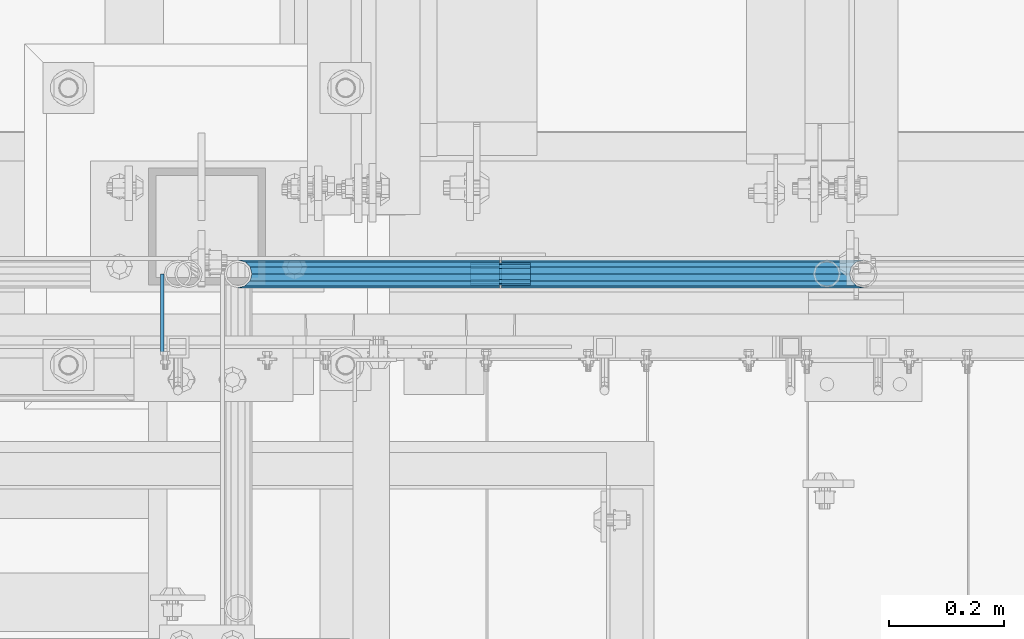
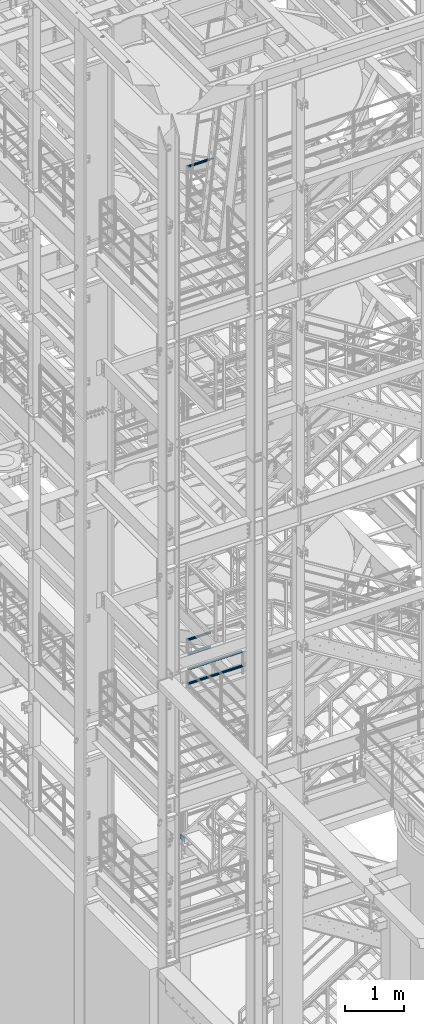
# One storey, part 1173 of 1876: 9 beams, 4 elements without a shape of their own.
"""IFC2X3 building model written with IfcOpenShell, lengths in millimetres."""

from ifc_helpers import new_model, si_unit, frame, origin_with_axes, place, context, subcontext, project, spatial, faceted_brep, material, type_object, element, aggregate, save


model = new_model("IFC2X3")

# Units and contexts
model_context = context("Model", 3, precision=1e-05, world=origin_with_axes())
body_context = subcontext(model_context, "Body", "Model", "MODEL_VIEW")
ifc_project = project(units=[si_unit("LENGTHUNIT", "METRE", prefix="MILLI"), si_unit("AREAUNIT", "SQUARE_METRE"), si_unit("VOLUMEUNIT", "CUBIC_METRE"), si_unit("MASSUNIT", "GRAM", prefix="KILO"), si_unit("TIMEUNIT", "SECOND"), si_unit("PLANEANGLEUNIT", "RADIAN"), si_unit("SOLIDANGLEUNIT", "STERADIAN"), si_unit("THERMODYNAMICTEMPERATUREUNIT", "DEGREE_CELSIUS"), si_unit("LUMINOUSINTENSITYUNIT", "LUMEN")], contexts=[model_context])

# Site, building, storey
site_placement = place(None, origin_with_axes())
site = spatial("IfcSite", under=ifc_project, at=site_placement, CompositionType="ELEMENT")
building_placement = place(site_placement, origin_with_axes())
building = spatial("IfcBuilding", under=site, at=building_placement, Name="Undefined", CompositionType="ELEMENT")
storey_placement = place(building_placement, origin_with_axes())
storey = spatial("IfcBuildingStorey", under=building, at=storey_placement, Name="Undefined", CompositionType="ELEMENT", Elevation=0.0)

# Assembly, beams
assembly_1_placement = place(storey_placement, origin_with_axes())
assembly_1 = element("IfcElementAssembly", 1, at=assembly_1_placement, inside=storey, Name="RAIL", AssemblyPlace="NOTDEFINED", PredefinedType="RIGID_FRAME")
ifc_material_1 = material()
beam_type_1 = type_object("IfcBeamType", Name="PIPE1-1/2SCH40", PredefinedType="NOTDEFINED")
beam_1_placement = place(assembly_1_placement, frame((2870.19999998823, -4654.55000114554, 8315.325), z_axis=(0.0, 0.0, 1.0), x_axis=(-1.0, 0.0, 0.0)))
beam_1 = element("IfcBeam", 2, at=beam_1_placement, type_object=beam_type_1, material=ifc_material_1, Name="RAIL", ObjectType="PIPE1-1/2SCH40", context=body_context, shape_type="Brep", body=[
    faceted_brep([(0.0, 24.1299999999992, 0.0), (12.0650000000064, 20.8971929933177, -12.0649999999987), (12.0650000000064, 20.8971929933177, 12.0649999999987), (12.0650000000064, -20.8971929933177, 12.0649999999987), (12.0650000000064, -20.8971929933177, -12.0649999999987), (0.0, -24.1299999999992, 0.0), (20.8971929933249, -12.0650000000005, 20.8971929933177), (20.8971929933249, -12.0650000000005, 15.8661214311796), (15.2545715621445, -17.7076214311801, 10.2235000000001), (12.5151929933249, -20.4470000000001, 0.0), (15.2545715621445, -17.7076214311801, -10.2235000000001), (20.8971929933249, -12.0650000000005, -15.8661214311796), (20.8971929933249, -12.0650000000005, -20.8971929933177), (24.1300000000063, 0.0, -20.4470000000001), (24.1300000000063, 0.0, -24.130000000001), (21.3906214311868, -10.2235000000001, -17.7076214311819), (21.3906214311868, 10.2235000000001, -17.7076214311819), (20.8971929933249, 12.0650000000005, -15.8661214311796), (20.8971929933249, 12.0650000000005, -20.8971929933177), (15.2545715621445, 17.7076214311801, -10.2235000000001), (12.5151929933249, 20.4470000000001, 0.0), (15.2545715621445, 17.7076214311801, 10.2235000000001), (20.8971929933249, 12.0650000000005, 15.8661214311796), (20.8971929933249, 12.0650000000005, 20.8971929933177), (21.3906214311868, 10.2235000000001, 17.7076214311819), (24.1300000000064, 0.0, 20.4470000000001), (24.1300000000064, 0.0, 24.130000000001), (21.3906214311868, -10.2235000000001, 17.7076214311819), (630.238000000001, -24.1300000000001, 0.0), (630.238000000001, -20.8971929933186, 12.0649999999987), (630.238000000001, -12.0649999999996, 20.8971929933177), (630.238000000001, 0.0, 24.130000000001), (630.238000000001, -12.0649999999996, -20.8971929933177), (630.238000000001, -20.8971929933186, -12.0649999999987), (630.238000000001, 0.0, -24.130000000001), (630.238000000001, 12.0649999999996, -20.8971929933177), (630.238000000001, 20.8971929933186, -12.0649999999987), (630.238000000001, 24.1300000000001, 0.0), (630.238000000001, 20.8971929933186, 12.0649999999987), (630.238000000001, 12.0649999999996, 20.8971929933177), (630.238000000001, -10.2235000000001, 17.7076214311819), (630.238000000001, 0.0, 20.4470000000001), (630.238000000001, 10.2235000000001, 17.7076214311819), (630.238000000001, 17.7076214311801, 10.2235000000001), (630.238000000001, 20.4470000000001, 0.0), (630.238000000001, 17.7076214311801, -10.2235000000001), (630.238000000001, 10.2235000000001, -17.7076214311819), (630.238000000001, 0.0, -20.4470000000001), (630.238000000001, -10.2235000000001, -17.7076214311819), (630.238000000001, -17.7076214311801, -10.2235000000001), (630.238000000001, -20.4470000000001, 0.0), (630.238000000001, -17.7076214311801, 10.2235000000001)], [[[0, 1, 2]], [[3, 4, 5]], [[6, 7, 8, 9, 10, 11, 12, 4, 3]], [[13, 14, 12, 11, 15]], [[16, 17, 18, 14, 13]], [[2, 1, 18, 17, 19, 20, 21, 22, 23]], [[23, 22, 24, 25, 26]], [[26, 25, 27, 7, 6]], [[28, 29, 3, 5]], [[29, 30, 6, 3]], [[30, 31, 26, 6]], [[32, 33, 4, 12]], [[34, 32, 12, 14]], [[35, 34, 14, 18]], [[36, 35, 18, 1]], [[37, 36, 1, 0]], [[38, 37, 0, 2]], [[39, 38, 2, 23]], [[31, 39, 23, 26]], [[33, 28, 5, 4]], [[32, 34, 35, 36, 37, 38, 39, 31, 30, 29, 28, 33], [40, 41, 42, 43, 44, 45, 46, 47, 48, 49, 50, 51]], [[42, 41, 25, 24]], [[21, 43, 42, 24, 22]], [[44, 43, 21, 20]], [[45, 44, 20, 19]], [[46, 45, 19, 17, 16]], [[47, 46, 16, 13]], [[48, 47, 13, 15]], [[10, 49, 48, 15, 11]], [[50, 49, 10, 9]], [[51, 50, 9, 8]], [[40, 51, 8, 7, 27]], [[41, 40, 27, 25]]]),
])
beam_2_placement = place(assembly_1_placement, frame((2238.37499998823, -4654.55000114554, 8620.125), z_axis=(0.0, 0.0, -1.0), x_axis=(1.0, 0.0, 0.0)))
beam_2 = element("IfcBeam", 3, at=beam_2_placement, type_object=beam_type_1, material=ifc_material_1, Name="RAIL", ObjectType="PIPE1-1/2SCH40", context=body_context, shape_type="Brep", body=[
    faceted_brep([(610.92780700668, -12.0649999999996, 20.8971929933177), (610.92780700668, -12.0650000000051, 15.866121431176), (610.434378568817, -10.2235000000001, 17.7076214311819), (607.694999999998, 0.0, 20.4470000000001), (607.694999999998, 0.0, 24.130000000001), (610.434378568819, 10.2235000000001, 17.7076214311819), (610.92780700668, 12.0649999999941, 15.8661214311869), (610.92780700668, 12.0649999999996, 20.8971929933177), (631.825, 24.1300000000001, 0.0), (619.759999999998, 20.8971929933186, 12.0649999999987), (619.759999999998, 20.8971929933186, -12.0649999999987), (616.570428437866, 17.7076214311801, 10.2235000000001), (619.309807006685, 20.4470000000001, 0.0), (616.570428437866, 17.7076214311801, -10.2235000000001), (610.92780700668, 12.0649999999941, -15.8661214311869), (610.92780700668, 12.0649999999996, -20.8971929933177), (610.434378568819, 10.2235000000001, -17.7076214311819), (607.694999999998, 0.0, -20.4470000000001), (607.694999999998, 0.0, -24.130000000001), (610.92780700668, -12.0650000000051, -15.866121431176), (610.92780700668, -12.0649999999996, -20.8971929933177), (610.434378568817, -10.2235000000001, -17.7076214311819), (631.824999999998, -24.1300000000056, 0.0), (619.759999999998, -20.8971929933186, -12.0649999999987), (619.759999999998, -20.8971929933186, 12.0649999999987), (616.570428437855, -17.7076214311801, -10.2235000000001), (619.309807006674, -20.4470000000001, 0.0), (616.570428437855, -17.7076214311801, 10.2235000000001), (1.58700000000044, -20.8971929933186, -12.0649999999996), (1.58700000000044, -12.0649999999996, -20.8971929933186), (1.58700000000044, 0.0, -24.1300000000001), (1.58700000000044, 12.0649999999996, -20.8971929933186), (1.58700000000044, 20.8971929933186, -12.0649999999996), (1.58700000000044, 24.1300000000001, 0.0), (1.58700000000044, 20.8971929933186, 12.0649999999996), (1.58700000000044, 12.0649999999996, 20.8971929933186), (1.58700000000044, 0.0, 24.1300000000001), (1.58700000000044, -12.0649999999996, 20.8971929933186), (1.58700000000044, -20.8971929933186, 12.0649999999996), (1.58700000000044, -24.1300000000001, 0.0), (1.58700000000044, -17.7076214311801, -10.2235000000001), (1.58700000000044, -10.2235000000001, -17.7076214311801), (1.58700000000044, 0.0, -20.4470000000001), (1.58700000000044, 10.2235000000001, -17.7076214311801), (1.58700000000044, 17.7076214311801, -10.2235000000001), (1.58700000000044, 20.4470000000001, 0.0), (1.58700000000044, 17.7076214311801, 10.2235000000001), (1.58700000000044, 10.2235000000001, 17.7076214311801), (1.58700000000044, 0.0, 20.4470000000001), (1.58700000000044, -10.2235000000001, 17.7076214311801), (1.58700000000044, -17.7076214311801, 10.2235000000001), (1.58700000000044, -20.4470000000001, 0.0)], [[[0, 1, 2, 3, 4]], [[4, 3, 5, 6, 7]], [[8, 9, 10]], [[7, 6, 11, 12, 13, 14, 15, 10, 9]], [[16, 17, 18, 15, 14]], [[19, 20, 18, 17, 21]], [[22, 23, 24]], [[24, 23, 20, 19, 25, 26, 27, 1, 0]], [[28, 29, 20, 23]], [[29, 30, 18, 20]], [[30, 31, 15, 18]], [[31, 32, 10, 15]], [[32, 33, 8, 10]], [[33, 34, 9, 8]], [[34, 35, 7, 9]], [[35, 36, 4, 7]], [[36, 37, 0, 4]], [[37, 38, 24, 0]], [[38, 39, 22, 24]], [[39, 28, 23, 22]], [[38, 37, 36, 35, 34, 33, 32, 31, 30, 29, 28, 39], [40, 41, 42, 43, 44, 45, 46, 47, 48, 49, 50, 51]], [[40, 51, 26, 25]], [[21, 41, 40, 25, 19]], [[42, 41, 21, 17]], [[43, 42, 17, 16]], [[44, 43, 16, 14, 13]], [[45, 44, 13, 12]], [[46, 45, 12, 11]], [[5, 47, 46, 11, 6]], [[48, 47, 5, 3]], [[49, 48, 3, 2]], [[50, 49, 2, 1, 27]], [[51, 50, 27, 26]]]),
])
aggregate(assembly_1, [beam_1, beam_2])

assembly_2_placement = place(storey_placement, origin_with_axes())
assembly_2 = element("IfcElementAssembly", 4, at=assembly_2_placement, inside=storey, Name="RAIL", AssemblyPlace="NOTDEFINED", PredefinedType="RIGID_FRAME")
beam_3_placement = place(assembly_2_placement, frame((1781.17499999994, -4654.55000114555, 9229.725), z_axis=(0.0, 0.0, 1.0), x_axis=(1.0, 0.0, 0.0)))
beam_3 = element("IfcBeam", 5, at=beam_3_placement, type_object=beam_type_1, material=ifc_material_1, Name="RAIL", ObjectType="PIPE1-1/2SCH40", context=body_context, shape_type="Brep", body=[
    faceted_brep([(0.0, 24.1299999999992, 0.0), (12.0650000000064, 20.8971929933177, -12.0649999999987), (12.0650000000064, 20.8971929933177, 12.0649999999987), (12.0650000000064, -20.8971929933177, 12.0649999999987), (12.0650000000064, -20.8971929933177, -12.0649999999987), (0.0, -24.1299999999992, 0.0), (20.8971929933249, -12.0650000000005, 20.8971929933177), (20.8971929933249, -12.0650000000005, 15.8661214311796), (15.2545715621445, -17.7076214311801, 10.2235000000001), (12.5151929933249, -20.4470000000001, 0.0), (15.2545715621445, -17.7076214311801, -10.2235000000001), (20.8971929933249, -12.0650000000005, -15.8661214311796), (20.8971929933249, -12.0650000000005, -20.8971929933177), (24.1300000000063, 0.0, -20.4470000000001), (24.1300000000063, 0.0, -24.130000000001), (21.3906214311868, -10.2235000000001, -17.7076214311819), (21.3906214311868, 10.2235000000001, -17.7076214311819), (20.8971929933249, 12.0650000000005, -15.8661214311796), (20.8971929933249, 12.0650000000005, -20.8971929933177), (15.2545715621445, 17.7076214311801, -10.2235000000001), (12.5151929933249, 20.4470000000001, 0.0), (15.2545715621445, 17.7076214311801, 10.2235000000001), (20.8971929933249, 12.0650000000005, 15.8661214311796), (20.8971929933249, 12.0650000000005, 20.8971929933177), (21.3906214311868, 10.2235000000001, 17.7076214311819), (24.1300000000064, 0.0, 20.4470000000001), (24.1300000000064, 0.0, 24.130000000001), (21.3906214311868, -10.2235000000001, 17.7076214311819), (455.612999922148, -24.1300000000001, 0.0), (455.612999922148, -20.8971929933186, 12.0649999999996), (455.612999922148, -12.0649999999996, 20.8971929933186), (455.612999922148, 0.0, 24.1300000000001), (455.612999922148, -12.0649999999996, -20.8971929933186), (455.612999922148, -20.8971929933186, -12.0649999999996), (455.612999922148, 0.0, -24.1300000000001), (455.612999922148, 12.0649999999996, -20.8971929933186), (455.612999922148, 20.8971929933186, -12.0649999999996), (455.612999922148, 24.1300000000001, 0.0), (455.612999922148, 20.8971929933186, 12.0649999999996), (455.612999922148, 12.0649999999996, 20.8971929933186), (455.612999922148, -10.2235000000001, 17.7076214311801), (455.612999922148, 0.0, 20.4470000000001), (455.612999922148, 10.2235000000001, 17.7076214311801), (455.612999922148, 17.7076214311801, 10.2235000000001), (455.612999922148, 20.4470000000001, 0.0), (455.612999922148, 17.7076214311801, -10.2235000000001), (455.612999922148, 10.2235000000001, -17.7076214311801), (455.612999922148, 0.0, -20.4470000000001), (455.612999922148, -10.2235000000001, -17.7076214311801), (455.612999922148, -17.7076214311801, -10.2235000000001), (455.612999922148, -20.4470000000001, 0.0), (455.612999922148, -17.7076214311801, 10.2235000000001)], [[[0, 1, 2]], [[3, 4, 5]], [[6, 7, 8, 9, 10, 11, 12, 4, 3]], [[13, 14, 12, 11, 15]], [[16, 17, 18, 14, 13]], [[2, 1, 18, 17, 19, 20, 21, 22, 23]], [[23, 22, 24, 25, 26]], [[26, 25, 27, 7, 6]], [[28, 29, 3, 5]], [[29, 30, 6, 3]], [[30, 31, 26, 6]], [[32, 33, 4, 12]], [[34, 32, 12, 14]], [[35, 34, 14, 18]], [[36, 35, 18, 1]], [[37, 36, 1, 0]], [[38, 37, 0, 2]], [[39, 38, 2, 23]], [[31, 39, 23, 26]], [[33, 28, 5, 4]], [[32, 34, 35, 36, 37, 38, 39, 31, 30, 29, 28, 33], [40, 41, 42, 43, 44, 45, 46, 47, 48, 49, 50, 51]], [[42, 41, 25, 24]], [[21, 43, 42, 24, 22]], [[44, 43, 21, 20]], [[45, 44, 20, 19]], [[46, 45, 19, 17, 16]], [[47, 46, 16, 13]], [[48, 47, 13, 15]], [[10, 49, 48, 15, 11]], [[50, 49, 10, 9]], [[51, 50, 9, 8]], [[40, 51, 8, 7, 27]], [[41, 40, 27, 25]]]),
])
beam_4_placement = place(assembly_2_placement, frame((1781.17499999995, -4654.55000114554, 8924.925), z_axis=(0.0, 0.0, 1.0), x_axis=(1.0, 0.0, 0.0)))
beam_4 = element("IfcBeam", 6, at=beam_4_placement, type_object=beam_type_1, material=ifc_material_1, Name="RAIL", ObjectType="PIPE1-1/2SCH40", context=body_context, shape_type="Brep", body=[
    faceted_brep([(0.0, 24.1299999999992, 0.0), (12.0650000000064, 20.8971929933177, -12.0649999999987), (12.0650000000064, 20.8971929933177, 12.0649999999987), (12.0650000000064, -20.8971929933177, 12.0649999999987), (12.0650000000064, -20.8971929933177, -12.0649999999987), (0.0, -24.1299999999992, 0.0), (20.8971929933249, -12.0650000000005, 20.8971929933177), (20.8971929933249, -12.0650000000005, 15.8661214311796), (15.2545715621445, -17.7076214311801, 10.2235000000001), (12.5151929933249, -20.4470000000001, 0.0), (15.2545715621445, -17.7076214311801, -10.2235000000001), (20.8971929933249, -12.0650000000005, -15.8661214311796), (20.8971929933249, -12.0650000000005, -20.8971929933177), (24.1300000000063, 0.0, -20.4470000000001), (24.1300000000063, 0.0, -24.130000000001), (21.3906214311868, -10.2235000000001, -17.7076214311819), (21.3906214311868, 10.2235000000001, -17.7076214311819), (20.8971929933249, 12.0650000000005, -15.8661214311796), (20.8971929933249, 12.0650000000005, -20.8971929933177), (15.2545715621445, 17.7076214311801, -10.2235000000001), (12.5151929933249, 20.4470000000001, 0.0), (15.2545715621445, 17.7076214311801, 10.2235000000001), (20.8971929933249, 12.0650000000005, 15.8661214311796), (20.8971929933249, 12.0650000000005, 20.8971929933177), (21.3906214311868, 10.2235000000001, 17.7076214311819), (24.1300000000064, 0.0, 20.4470000000001), (24.1300000000064, 0.0, 24.130000000001), (21.3906214311868, -10.2235000000001, 17.7076214311819), (455.612999922148, -24.1300000000001, 0.0), (455.612999922148, -20.8971929933186, 12.0649999999996), (455.612999922148, -12.0649999999996, 20.8971929933186), (455.612999922148, 0.0, 24.1300000000001), (455.612999922148, -12.0649999999996, -20.8971929933186), (455.612999922148, -20.8971929933186, -12.0649999999996), (455.612999922148, 0.0, -24.1300000000001), (455.612999922148, 12.0649999999996, -20.8971929933186), (455.612999922148, 20.8971929933186, -12.0649999999996), (455.612999922148, 24.1300000000001, 0.0), (455.612999922148, 20.8971929933186, 12.0649999999996), (455.612999922148, 12.0649999999996, 20.8971929933186), (455.612999922148, -10.2235000000001, 17.7076214311801), (455.612999922148, 0.0, 20.4470000000001), (455.612999922148, 10.2235000000001, 17.7076214311801), (455.612999922148, 17.7076214311801, 10.2235000000001), (455.612999922148, 20.4470000000001, 0.0), (455.612999922148, 17.7076214311801, -10.2235000000001), (455.612999922148, 10.2235000000001, -17.7076214311801), (455.612999922148, 0.0, -20.4470000000001), (455.612999922148, -10.2235000000001, -17.7076214311801), (455.612999922148, -17.7076214311801, -10.2235000000001), (455.612999922148, -20.4470000000001, 0.0), (455.612999922148, -17.7076214311801, 10.2235000000001)], [[[0, 1, 2]], [[3, 4, 5]], [[6, 7, 8, 9, 10, 11, 12, 4, 3]], [[13, 14, 12, 11, 15]], [[16, 17, 18, 14, 13]], [[2, 1, 18, 17, 19, 20, 21, 22, 23]], [[23, 22, 24, 25, 26]], [[26, 25, 27, 7, 6]], [[28, 29, 3, 5]], [[29, 30, 6, 3]], [[30, 31, 26, 6]], [[32, 33, 4, 12]], [[34, 32, 12, 14]], [[35, 34, 14, 18]], [[36, 35, 18, 1]], [[37, 36, 1, 0]], [[38, 37, 0, 2]], [[39, 38, 2, 23]], [[31, 39, 23, 26]], [[33, 28, 5, 4]], [[32, 34, 35, 36, 37, 38, 39, 31, 30, 29, 28, 33], [40, 41, 42, 43, 44, 45, 46, 47, 48, 49, 50, 51]], [[42, 41, 25, 24]], [[21, 43, 42, 24, 22]], [[44, 43, 21, 20]], [[45, 44, 20, 19]], [[46, 45, 19, 17, 16]], [[47, 46, 16, 13]], [[48, 47, 13, 15]], [[10, 49, 48, 15, 11]], [[50, 49, 10, 9]], [[51, 50, 9, 8]], [[40, 51, 8, 7, 27]], [[41, 40, 27, 25]]]),
])
beam_5_placement = place(assembly_2_placement, frame((1781.17499999995, -4654.55000114555, 8620.125), z_axis=(0.0, 0.0, 1.0), x_axis=(1.0, 0.0, 0.0)))
beam_5 = element("IfcBeam", 7, at=beam_5_placement, type_object=beam_type_1, material=ifc_material_1, Name="RAIL", ObjectType="PIPE1-1/2SCH40", context=body_context, shape_type="Brep", body=[
    faceted_brep([(0.0, 24.1299999999992, 0.0), (12.0650000000064, 20.8971929933177, -12.0649999999987), (12.0650000000064, 20.8971929933177, 12.0649999999987), (12.0650000000064, -20.8971929933177, 12.0649999999987), (12.0650000000064, -20.8971929933177, -12.0649999999987), (0.0, -24.1299999999992, 0.0), (20.8971929933249, -12.0650000000005, 20.8971929933177), (20.8971929933249, -12.0650000000005, 15.8661214311796), (15.2545715621445, -17.7076214311801, 10.2235000000001), (12.5151929933249, -20.4470000000001, 0.0), (15.2545715621445, -17.7076214311801, -10.2235000000001), (20.8971929933249, -12.0650000000005, -15.8661214311796), (20.8971929933249, -12.0650000000005, -20.8971929933177), (24.1300000000063, 0.0, -20.4470000000001), (24.1300000000063, 0.0, -24.130000000001), (21.3906214311868, -10.2235000000001, -17.7076214311819), (21.3906214311868, 10.2235000000001, -17.7076214311819), (20.8971929933249, 12.0650000000005, -15.8661214311796), (20.8971929933249, 12.0650000000005, -20.8971929933177), (15.2545715621445, 17.7076214311801, -10.2235000000001), (12.5151929933249, 20.4470000000001, 0.0), (15.2545715621445, 17.7076214311801, 10.2235000000001), (20.8971929933249, 12.0650000000005, 15.8661214311796), (20.8971929933249, 12.0650000000005, 20.8971929933177), (21.3906214311868, 10.2235000000001, 17.7076214311819), (24.1300000000064, 0.0, 20.4470000000001), (24.1300000000064, 0.0, 24.130000000001), (21.3906214311868, -10.2235000000001, 17.7076214311819), (455.612999922148, -24.1300000000001, 0.0), (455.612999922148, -20.8971929933186, 12.0649999999996), (455.612999922148, -12.0649999999996, 20.8971929933186), (455.612999922148, 0.0, 24.1300000000001), (455.612999922148, -12.0649999999996, -20.8971929933186), (455.612999922148, -20.8971929933186, -12.0649999999996), (455.612999922148, 0.0, -24.1300000000001), (455.612999922148, 12.0649999999996, -20.8971929933186), (455.612999922148, 20.8971929933186, -12.0649999999996), (455.612999922148, 24.1300000000001, 0.0), (455.612999922148, 20.8971929933186, 12.0649999999996), (455.612999922148, 12.0649999999996, 20.8971929933186), (455.612999922148, -10.2235000000001, 17.7076214311801), (455.612999922148, 0.0, 20.4470000000001), (455.612999922148, 10.2235000000001, 17.7076214311801), (455.612999922148, 17.7076214311801, 10.2235000000001), (455.612999922148, 20.4470000000001, 0.0), (455.612999922148, 17.7076214311801, -10.2235000000001), (455.612999922148, 10.2235000000001, -17.7076214311801), (455.612999922148, 0.0, -20.4470000000001), (455.612999922148, -10.2235000000001, -17.7076214311801), (455.612999922148, -17.7076214311801, -10.2235000000001), (455.612999922148, -20.4470000000001, 0.0), (455.612999922148, -17.7076214311801, 10.2235000000001)], [[[0, 1, 2]], [[3, 4, 5]], [[6, 7, 8, 9, 10, 11, 12, 4, 3]], [[13, 14, 12, 11, 15]], [[16, 17, 18, 14, 13]], [[2, 1, 18, 17, 19, 20, 21, 22, 23]], [[23, 22, 24, 25, 26]], [[26, 25, 27, 7, 6]], [[28, 29, 3, 5]], [[29, 30, 6, 3]], [[30, 31, 26, 6]], [[32, 33, 4, 12]], [[34, 32, 12, 14]], [[35, 34, 14, 18]], [[36, 35, 18, 1]], [[37, 36, 1, 0]], [[38, 37, 0, 2]], [[39, 38, 2, 23]], [[31, 39, 23, 26]], [[33, 28, 5, 4]], [[32, 34, 35, 36, 37, 38, 39, 31, 30, 29, 28, 33], [40, 41, 42, 43, 44, 45, 46, 47, 48, 49, 50, 51]], [[42, 41, 25, 24]], [[21, 43, 42, 24, 22]], [[44, 43, 21, 20]], [[45, 44, 20, 19]], [[46, 45, 19, 17, 16]], [[47, 46, 16, 13]], [[48, 47, 13, 15]], [[10, 49, 48, 15, 11]], [[50, 49, 10, 9]], [[51, 50, 9, 8]], [[40, 51, 8, 7, 27]], [[41, 40, 27, 25]]]),
])
beam_6_placement = place(assembly_2_placement, frame((1781.17499999995, -4654.55000114554, 8315.325), z_axis=(0.0, 0.0, 1.0), x_axis=(1.0, 0.0, 0.0)))
beam_6 = element("IfcBeam", 8, at=beam_6_placement, type_object=beam_type_1, material=ifc_material_1, Name="RAIL", ObjectType="PIPE1-1/2SCH40", context=body_context, shape_type="Brep", body=[
    faceted_brep([(0.0, 24.1299999999992, 0.0), (12.0650000000064, 20.8971929933177, -12.0649999999987), (12.0650000000064, 20.8971929933177, 12.0649999999987), (12.0650000000064, -20.8971929933177, 12.0649999999987), (12.0650000000064, -20.8971929933177, -12.0649999999987), (0.0, -24.1299999999992, 0.0), (20.8971929933249, -12.0650000000005, 20.8971929933177), (20.8971929933249, -12.0650000000005, 15.8661214311796), (15.2545715621445, -17.7076214311801, 10.2235000000001), (12.5151929933249, -20.4470000000001, 0.0), (15.2545715621445, -17.7076214311801, -10.2235000000001), (20.8971929933249, -12.0650000000005, -15.8661214311796), (20.8971929933249, -12.0650000000005, -20.8971929933177), (24.1300000000063, 0.0, -20.4470000000001), (24.1300000000063, 0.0, -24.130000000001), (21.3906214311868, -10.2235000000001, -17.7076214311819), (21.3906214311868, 10.2235000000001, -17.7076214311819), (20.8971929933249, 12.0650000000005, -15.8661214311796), (20.8971929933249, 12.0650000000005, -20.8971929933177), (15.2545715621445, 17.7076214311801, -10.2235000000001), (12.5151929933249, 20.4470000000001, 0.0), (15.2545715621445, 17.7076214311801, 10.2235000000001), (20.8971929933249, 12.0650000000005, 15.8661214311796), (20.8971929933249, 12.0650000000005, 20.8971929933177), (21.3906214311868, 10.2235000000001, 17.7076214311819), (24.1300000000064, 0.0, 20.4470000000001), (24.1300000000064, 0.0, 24.130000000001), (21.3906214311868, -10.2235000000001, 17.7076214311819), (455.612999922148, -24.1300000000001, 0.0), (455.612999922148, -20.8971929933186, 12.0649999999996), (455.612999922148, -12.0649999999996, 20.8971929933186), (455.612999922148, 0.0, 24.1300000000001), (455.612999922148, -12.0649999999996, -20.8971929933186), (455.612999922148, -20.8971929933186, -12.0649999999996), (455.612999922148, 0.0, -24.1300000000001), (455.612999922148, 12.0649999999996, -20.8971929933186), (455.612999922148, 20.8971929933186, -12.0649999999996), (455.612999922148, 24.1300000000001, 0.0), (455.612999922148, 20.8971929933186, 12.0649999999996), (455.612999922148, 12.0649999999996, 20.8971929933186), (455.612999922148, -10.2235000000001, 17.7076214311801), (455.612999922148, 0.0, 20.4470000000001), (455.612999922148, 10.2235000000001, 17.7076214311801), (455.612999922148, 17.7076214311801, 10.2235000000001), (455.612999922148, 20.4470000000001, 0.0), (455.612999922148, 17.7076214311801, -10.2235000000001), (455.612999922148, 10.2235000000001, -17.7076214311801), (455.612999922148, 0.0, -20.4470000000001), (455.612999922148, -10.2235000000001, -17.7076214311801), (455.612999922148, -17.7076214311801, -10.2235000000001), (455.612999922148, -20.4470000000001, 0.0), (455.612999922148, -17.7076214311801, 10.2235000000001)], [[[0, 1, 2]], [[3, 4, 5]], [[6, 7, 8, 9, 10, 11, 12, 4, 3]], [[13, 14, 12, 11, 15]], [[16, 17, 18, 14, 13]], [[2, 1, 18, 17, 19, 20, 21, 22, 23]], [[23, 22, 24, 25, 26]], [[26, 25, 27, 7, 6]], [[28, 29, 3, 5]], [[29, 30, 6, 3]], [[30, 31, 26, 6]], [[32, 33, 4, 12]], [[34, 32, 12, 14]], [[35, 34, 14, 18]], [[36, 35, 18, 1]], [[37, 36, 1, 0]], [[38, 37, 0, 2]], [[39, 38, 2, 23]], [[31, 39, 23, 26]], [[33, 28, 5, 4]], [[32, 34, 35, 36, 37, 38, 39, 31, 30, 29, 28, 33], [40, 41, 42, 43, 44, 45, 46, 47, 48, 49, 50, 51]], [[42, 41, 25, 24]], [[21, 43, 42, 24, 22]], [[44, 43, 21, 20]], [[45, 44, 20, 19]], [[46, 45, 19, 17, 16]], [[47, 46, 16, 13]], [[48, 47, 13, 15]], [[10, 49, 48, 15, 11]], [[50, 49, 10, 9]], [[51, 50, 9, 8]], [[40, 51, 8, 7, 27]], [[41, 40, 27, 25]]]),
])
aggregate(assembly_2, [beam_3, beam_4, beam_5, beam_6])

# Assembly, beam
assembly_3_placement = place(storey_placement, origin_with_axes())
assembly_3 = element("IfcElementAssembly", 9, at=assembly_3_placement, inside=storey, Name="RAIL", AssemblyPlace="NOTDEFINED", PredefinedType="RIGID_FRAME")
beam_7_placement = place(assembly_3_placement, frame((1781.17499999994, -4654.55000114555, 19059.525), z_axis=(0.0, 0.0, 1.0), x_axis=(1.0, 0.0, 0.0)))
beam_7 = element("IfcBeam", 10, at=beam_7_placement, type_object=beam_type_1, material=ifc_material_1, Name="RAIL", ObjectType="PIPE1-1/2SCH40", context=body_context, shape_type="Brep", body=[
    faceted_brep([(0.0, 24.1299999999992, 0.0), (12.0650000000064, 20.8971929933177, -12.0649999999987), (12.0650000000064, 20.8971929933177, 12.0649999999987), (12.0650000000064, -20.8971929933177, 12.0649999999987), (12.0650000000064, -20.8971929933177, -12.0649999999987), (0.0, -24.1299999999992, 0.0), (20.8971929933249, -12.0650000000005, 20.8971929933177), (20.8971929933249, -12.0650000000005, 15.8661214311796), (15.2545715621445, -17.7076214311801, 10.2235000000001), (12.5151929933249, -20.4470000000001, 0.0), (15.2545715621445, -17.7076214311801, -10.2235000000001), (20.8971929933249, -12.0650000000005, -15.8661214311796), (20.8971929933249, -12.0650000000005, -20.8971929933177), (24.1300000000063, 0.0, -20.4470000000001), (24.1300000000063, 0.0, -24.130000000001), (21.3906214311868, -10.2235000000001, -17.7076214311819), (21.3906214311868, 10.2235000000001, -17.7076214311819), (20.8971929933249, 12.0650000000005, -15.8661214311796), (20.8971929933249, 12.0650000000005, -20.8971929933177), (15.2545715621445, 17.7076214311801, -10.2235000000001), (12.5151929933249, 20.4470000000001, 0.0), (15.2545715621445, 17.7076214311801, 10.2235000000001), (20.8971929933249, 12.0650000000005, 15.8661214311796), (20.8971929933249, 12.0650000000005, 20.8971929933177), (21.3906214311868, 10.2235000000001, 17.7076214311819), (24.1300000000064, 0.0, 20.4470000000001), (24.1300000000064, 0.0, 24.130000000001), (21.3906214311868, -10.2235000000001, 17.7076214311819), (455.612999922148, -24.1300000000001, 0.0), (455.612999922148, -20.8971929933186, 12.0649999999996), (455.612999922148, -12.0649999999996, 20.8971929933186), (455.612999922148, 0.0, 24.1300000000001), (455.612999922148, -12.0649999999996, -20.8971929933186), (455.612999922148, -20.8971929933186, -12.0649999999996), (455.612999922148, 0.0, -24.1300000000001), (455.612999922148, 12.0649999999996, -20.8971929933186), (455.612999922148, 20.8971929933186, -12.0649999999996), (455.612999922148, 24.1300000000001, 0.0), (455.612999922148, 20.8971929933186, 12.0649999999996), (455.612999922148, 12.0649999999996, 20.8971929933186), (455.612999922148, -10.2235000000001, 17.7076214311801), (455.612999922148, 0.0, 20.4470000000001), (455.612999922148, 10.2235000000001, 17.7076214311801), (455.612999922148, 17.7076214311801, 10.2235000000001), (455.612999922148, 20.4470000000001, 0.0), (455.612999922148, 17.7076214311801, -10.2235000000001), (455.612999922148, 10.2235000000001, -17.7076214311801), (455.612999922148, 0.0, -20.4470000000001), (455.612999922148, -10.2235000000001, -17.7076214311801), (455.612999922148, -17.7076214311801, -10.2235000000001), (455.612999922148, -20.4470000000001, 0.0), (455.612999922148, -17.7076214311801, 10.2235000000001)], [[[0, 1, 2]], [[3, 4, 5]], [[6, 7, 8, 9, 10, 11, 12, 4, 3]], [[13, 14, 12, 11, 15]], [[16, 17, 18, 14, 13]], [[2, 1, 18, 17, 19, 20, 21, 22, 23]], [[23, 22, 24, 25, 26]], [[26, 25, 27, 7, 6]], [[28, 29, 3, 5]], [[29, 30, 6, 3]], [[30, 31, 26, 6]], [[32, 33, 4, 12]], [[34, 32, 12, 14]], [[35, 34, 14, 18]], [[36, 35, 18, 1]], [[37, 36, 1, 0]], [[38, 37, 0, 2]], [[39, 38, 2, 23]], [[31, 39, 23, 26]], [[33, 28, 5, 4]], [[32, 34, 35, 36, 37, 38, 39, 31, 30, 29, 28, 33], [40, 41, 42, 43, 44, 45, 46, 47, 48, 49, 50, 51]], [[42, 41, 25, 24]], [[21, 43, 42, 24, 22]], [[44, 43, 21, 20]], [[45, 44, 20, 19]], [[46, 45, 19, 17, 16]], [[47, 46, 16, 13]], [[48, 47, 13, 15]], [[10, 49, 48, 15, 11]], [[50, 49, 10, 9]], [[51, 50, 9, 8]], [[40, 51, 8, 7, 27]], [[41, 40, 27, 25]]]),
])

assembly_4_placement = place(storey_placement, origin_with_axes())
assembly_4 = element("IfcElementAssembly", 11, at=assembly_4_placement, inside=storey, Name="RAIL", AssemblyPlace="NOTDEFINED", PredefinedType="RIGID_FRAME")
ifc_material_2 = material(Name="STEEL/A36")
beam_type_2 = type_object("IfcBeamType", PredefinedType="NOTDEFINED")
beam_8_placement = place(assembly_4_placement, frame((1649.41250031178, -4654.55000108115, 5197.47500000002), z_axis=(0.0, 0.0, 1.0), x_axis=(0.0, -1.0, 0.0)))
beam_8 = element("IfcBeam", 12, at=beam_8_placement, type_object=beam_type_2, material=ifc_material_2, Name="PLATE", context=body_context, shape_type="Brep", body=[
    faceted_brep([(0.0, 3.17500000000018, -50.8000000000002), (0.0, 3.17500000000018, 50.8000000000002), (139.700000095035, 3.17499999999995, 50.7999999999383), (139.70000009499, 3.17499999999995, -50.800000000062), (0.0, -3.17500000000018, 50.8000000000002), (139.700000095035, -3.17499999999995, 50.7999999999383), (0.0, -3.17500000000018, -50.8000000000002), (139.70000009499, -3.17499999999995, -50.800000000062)], [[[0, 1, 2, 3]], [[1, 4, 5, 2]], [[4, 6, 7, 5]], [[6, 0, 3, 7]], [[5, 7, 3, 2]], [[6, 4, 1, 0]]]),
])
aggregate(assembly_4, [beam_8])

# Beam
beam_type_3 = type_object("IfcBeamType", PredefinedType="NOTDEFINED")
beam_9_placement = place(assembly_3_placement, frame((2185.98799998822, -4654.54995231742, 19059.525), z_axis=(0.0, 0.0, 1.0), x_axis=(1.0, 0.0, 0.0)))
beam_9 = element("IfcBeam", 13, at=beam_9_placement, type_object=beam_type_3, material=ifc_material_2, Name="ROD", context=body_context, shape_type="Brep", body=[
    faceted_brep([(0.0, -18.8594999999996, 0.0), (0.0, -16.3328061026723, -9.42975000000024), (104.774, -16.3328061026723, -9.42975000000024), (104.774, -18.8594999999996, 0.0), (0.0, -9.42975000000024, -16.3328061026723), (104.774, -9.42975000000024, -16.3328061026723), (0.0, 0.0, -18.8594999999996), (104.774, 0.0, -18.8594999999996), (0.0, 9.42975000000024, -16.3328061026723), (104.774, 9.42975000000024, -16.3328061026723), (0.0, 16.3328061026723, -9.42975000000024), (104.774, 16.3328061026723, -9.42975000000024), (0.0, 18.8594999999996, 0.0), (104.774, 18.8594999999996, 0.0), (0.0, 16.3328061026723, 9.42975000000024), (104.774, 16.3328061026723, 9.42975000000024), (0.0, 9.42975000000024, 16.3328061026723), (104.774, 9.42975000000024, 16.3328061026723), (0.0, 0.0, 18.8594999999996), (104.774, 0.0, 18.8594999999996), (0.0, -9.42975000000024, 16.3328061026723), (104.774, -9.42975000000024, 16.3328061026723), (0.0, -16.3328061026723, 9.42975000000024), (104.774, -16.3328061026723, 9.42975000000024)], [[[0, 1, 2, 3]], [[1, 4, 5, 2]], [[4, 6, 7, 5]], [[6, 8, 9, 7]], [[8, 10, 11, 9]], [[10, 12, 13, 11]], [[12, 14, 15, 13]], [[14, 16, 17, 15]], [[16, 18, 19, 17]], [[18, 20, 21, 19]], [[20, 22, 23, 21]], [[22, 0, 3, 23]], [[5, 7, 9, 11, 13, 15, 17, 19, 21, 23, 3, 2]], [[22, 20, 18, 16, 14, 12, 10, 8, 6, 4, 1, 0]]]),
])

aggregate(assembly_3, [beam_9, beam_7])

save(model, "model.ifc")
